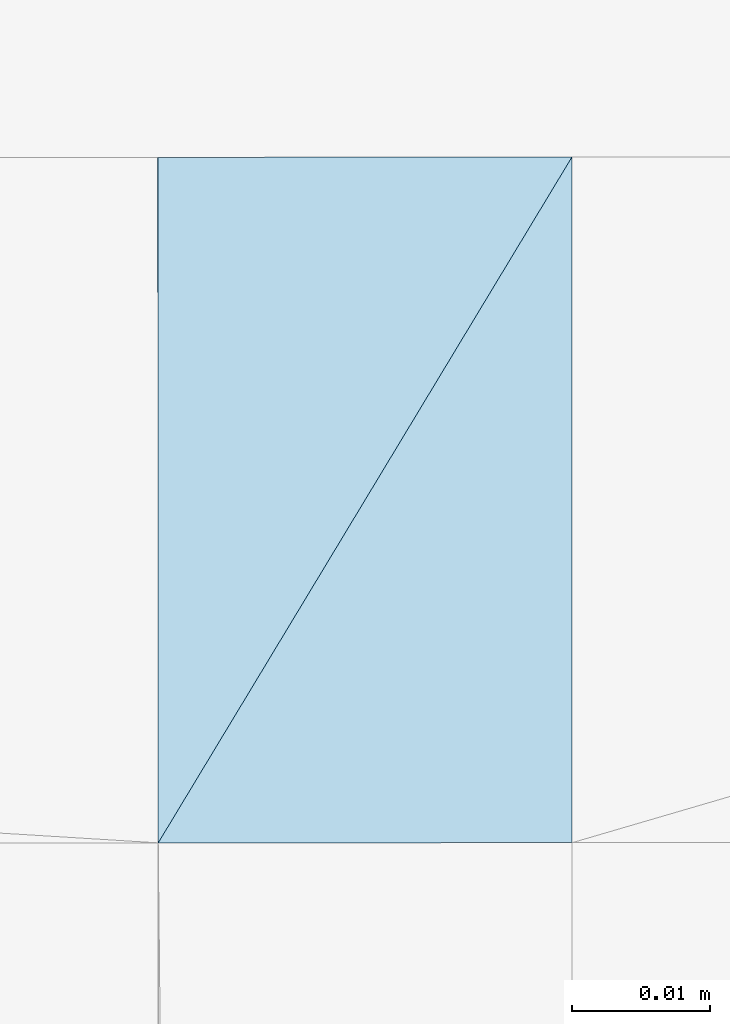
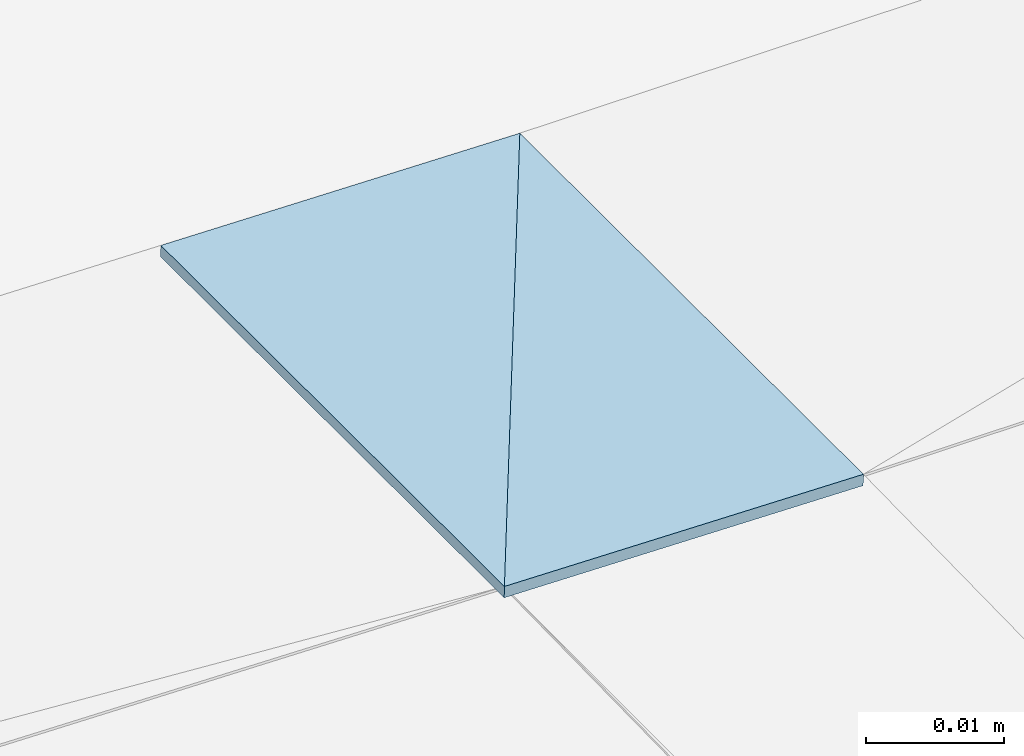
# One storey, part 194 of 275: 2 plates.
"""IFC2X3 building model written with IfcOpenShell, lengths in millimetres."""

from ifc_helpers import new_model, si_unit, frame, origin_with_axes, place, context, subcontext, project, spatial, polyline, outline, extrude, material, type_object, element, save


model = new_model("IFC2X3")

# Units and contexts
model_context = context("Model", 3, precision=1e-05, world=origin_with_axes())
body_context = subcontext(model_context, "Body", "Model", "MODEL_VIEW")
ifc_project = project(units=[si_unit("LENGTHUNIT", "METRE", prefix="MILLI"), si_unit("AREAUNIT", "SQUARE_METRE"), si_unit("VOLUMEUNIT", "CUBIC_METRE"), si_unit("MASSUNIT", "GRAM", prefix="KILO"), si_unit("TIMEUNIT", "SECOND"), si_unit("PLANEANGLEUNIT", "RADIAN"), si_unit("SOLIDANGLEUNIT", "STERADIAN"), si_unit("THERMODYNAMICTEMPERATUREUNIT", "DEGREE_CELSIUS"), si_unit("LUMINOUSINTENSITYUNIT", "LUMEN")], contexts=[model_context])

# Site, building, storey
site_placement = place(None, origin_with_axes())
site = spatial("IfcSite", under=ifc_project, at=site_placement, CompositionType="ELEMENT")
building_placement = place(site_placement, origin_with_axes())
building = spatial("IfcBuilding", under=site, at=building_placement, Name="Undefined", CompositionType="ELEMENT")
storey_placement = place(building_placement, origin_with_axes())
storey = spatial("IfcBuildingStorey", under=building, at=storey_placement, Name="Undefined", CompositionType="ELEMENT", Elevation=0.0)

# Plates
ifc_material = material()
plate_type = type_object("IfcPlateType", PredefinedType="NOTDEFINED")
plate_1_placement = place(storey_placement, frame((-94355.5164153553, 80803.8462044916, 42675.1490987391), z_axis=(-0.0199960066787066, -7.39668439559663e-06, -0.999800059843064), x_axis=(0.999800007538347, 0.000348176114235448, -0.0199955920071313)))
element("IfcPlate", 1, at=plate_1_placement, inside=storey, type_object=plate_type, material=ifc_material, Name="00_PR", context=body_context, shape_type="SweptSolid", body=[
    extrude(outline(polyline([(0.0, 0.0), (30.0066146850586, -1.45519152283669e-10), (0.00139427999965847, 49.6906700134277), (0.0, 0.0)])), frame((-8.85201319254618e-08, 2.18876761149539e-07, -0.5000001331573), z_axis=(0.0, 0.0, 1.0), x_axis=(1.0, 0.0, 0.0)), (0.0, 0.0, 1.0), 1.0),
])
plate_2_placement = place(storey_placement, frame((-94355.4977188827, 80754.1555382181, 42675.1490991787), z_axis=(-0.0199960066787066, -7.39668439559663e-06, -0.999800059843064), x_axis=(0.51650933680532, 0.856219167885969, -0.0103364180250134)))
element("IfcPlate", 2, at=plate_2_placement, inside=storey, type_object=plate_type, material=ifc_material, Name="00_PR", context=body_context, shape_type="SweptSolid", body=[
    extrude(outline(polyline([(0.0, 0.0), (58.0471878051758, -1.16415321826935e-10), (15.5113191604614, 25.6860198974609), (0.0, 0.0)])), frame((-8.85201319254618e-08, 2.18876761149539e-07, -0.5000001331573), z_axis=(0.0, 0.0, 1.0), x_axis=(1.0, 0.0, 0.0)), (0.0, 0.0, 1.0), 1.0),
])

save(model, "model.ifc")
